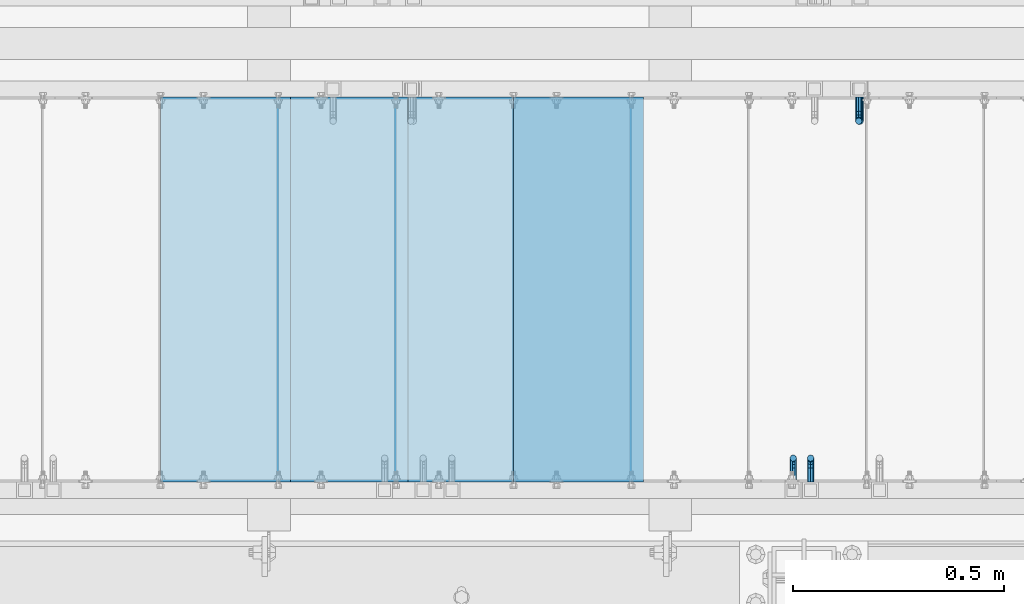
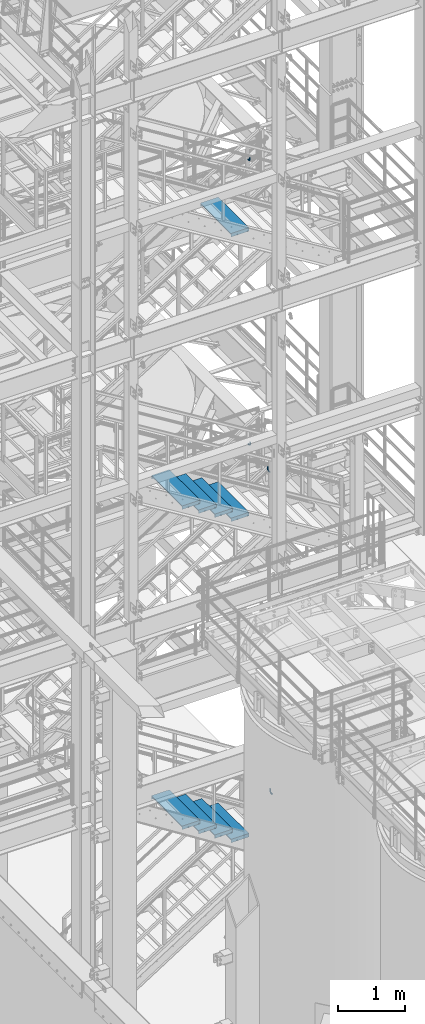
# One storey, part 1148 of 1876: 13 beams, 7 elements without a shape of their own.
"""IFC2X3 building model written with IfcOpenShell, lengths in millimetres."""

from ifc_helpers import new_model, si_unit, frame, origin_with_axes, place, context, subcontext, project, spatial, faceted_brep, material, type_object, element, aggregate, save


model = new_model("IFC2X3")

# Units and contexts
model_context = context("Model", 3, precision=1e-05, world=origin_with_axes())
body_context = subcontext(model_context, "Body", "Model", "MODEL_VIEW")
ifc_project = project(units=[si_unit("LENGTHUNIT", "METRE", prefix="MILLI"), si_unit("AREAUNIT", "SQUARE_METRE"), si_unit("VOLUMEUNIT", "CUBIC_METRE"), si_unit("MASSUNIT", "GRAM", prefix="KILO"), si_unit("TIMEUNIT", "SECOND"), si_unit("PLANEANGLEUNIT", "RADIAN"), si_unit("SOLIDANGLEUNIT", "STERADIAN"), si_unit("THERMODYNAMICTEMPERATUREUNIT", "DEGREE_CELSIUS"), si_unit("LUMINOUSINTENSITYUNIT", "LUMEN")], contexts=[model_context])

# Site, building, storey
site_placement = place(None, origin_with_axes())
site = spatial("IfcSite", under=ifc_project, at=site_placement, CompositionType="ELEMENT")
building_placement = place(site_placement, origin_with_axes())
building = spatial("IfcBuilding", under=site, at=building_placement, Name="Undefined", CompositionType="ELEMENT")
storey_placement = place(building_placement, origin_with_axes())
storey = spatial("IfcBuildingStorey", under=building, at=storey_placement, Name="Undefined", CompositionType="ELEMENT", Elevation=0.0)

# Assembly, beam
assembly_1_placement = place(storey_placement, origin_with_axes())
assembly_1 = element("IfcElementAssembly", 1, at=assembly_1_placement, inside=storey, Name="RAIL", AssemblyPlace="NOTDEFINED", PredefinedType="RIGID_FRAME")
ifc_material = material(Name="STEEL/A36")
beam_type_1 = type_object("IfcBeamType", PredefinedType="NOTDEFINED")
beam_1_placement = place(assembly_1_placement, frame((5054.60000035519, -6883.39999885446, 9800.9171377528), z_axis=(-0.851746923791363, 0.0, 0.523953411871657), x_axis=(0.0, 1.0, 0.0)))
beam_1 = element("IfcBeam", 2, at=beam_1_placement, type_object=beam_type_1, material=ifc_material, Name="BRACKET", context=body_context, shape_type="Brep", body=[
    faceted_brep([(0.0, -5.61266007566822, 5.61266007566883), (0.0, 0.0, 7.9375), (0.0, 5.61266007566822, 5.61266007566883), (0.0, 7.9375, 0.0), (0.0, 5.61266007566822, -5.61266007566883), (0.0, 0.0, -7.9375), (0.0, -5.61266007566822, -5.61266007566883), (0.0, -7.9375, 0.0), (23.8125, 7.9375, 0.0), (23.8125, 5.61266007566883, -5.61266007566792), (23.8125, 0.0, -7.9375), (23.8125, -5.61266007566883, -5.61266007566792), (23.8125, -7.9375, 0.0), (23.8125, -5.61266007566883, 5.61266007566792), (23.8125, 0.0, 7.9375), (23.8125, 5.61266007566883, 5.61266007566792), (37.2742680237907, 3.33192699189385, 7.01565649095653), (39.15743316105, 5.33771543479088, 1.59926141794483), (39.5250377726497, 2.95059483544173, -3.97508660603592), (38.1617440627024, -2.43109193407145, -6.44201010992776), (35.8661509970007, -7.65482575261558, -4.3564187624853), (33.9829858597423, -9.66061419551443, 1.05997631052549), (33.6153812481443, -7.27349359616528, 6.63432433450714), (34.9786749580899, -1.89180682665028, 9.10124783839899), (44.4449010004428, -7.27921686651098, 12.4153212945938), (48.6866038971966, -3.16305132232992, 11.0110522507902), (41.9258626896017, -12.0031473096369, 9.54377798901703), (42.605107443027, -14.5676282658369, 4.07853345752562), (46.0847428963316, -13.4704215714119, -0.778946175020906), (50.3264457930854, -9.35425602723262, -2.18321521882456), (52.8454841039247, -4.63032558410305, 0.688328086752222), (52.1662393505012, -2.0658446279067, 6.15357261824545), (56.3120829365644, -12.8834732957839, 16.9905845690854), (60.8584457511233, -13.1460552819772, 12.9695810055836), (50.7700310236578, -15.3420457780048, 17.3751827270333), (47.4787488596085, -19.0815743126295, 13.8980830945646), (48.3662248985192, -21.9114938009589, 8.59612347865811), (52.9125877130791, -22.1740757871521, 4.57511991515719), (58.4546396259857, -19.715503304933, 4.19052175720924), (61.7459217900359, -15.9759747703083, 7.66762138967886), (63.9107427334729, -26.2160548977063, 21.0096110902649), (64.8713398759373, -29.3590804831365, 15.9002591648249), (58.9897950832947, -24.3494927988595, 24.0439238549806), (52.991121319149, -24.8528009490874, 23.2257381938842), (49.4286631758196, -27.4311482600406, 19.0343361707063), (50.389260318284, -30.5741738454726, 13.9249842452672), (55.3102079684622, -32.4407359443194, 10.8906714805506), (61.3088817326088, -31.9374277940915, 11.7088571416479), (64.8713398759373, -56.6704316393188, 32.700878247072), (61.3088817326088, -56.6704314004855, 26.9234018184987), (55.3102079684622, -56.670431353863, 25.7956053568267), (50.389260318284, -56.6704315267634, 29.9781367337081), (49.4286631758196, -56.6704318179036, 37.0209257936175), (52.991121319149, -56.6704320567369, 42.7984022221907), (58.9897950832947, -56.6704321033558, 43.9261986838618), (63.9107427334739, -56.6704319304572, 39.7436673069795)], [[[0, 1, 2, 3, 4, 5, 6, 7]], [[4, 3, 8, 9]], [[5, 4, 9, 10]], [[6, 5, 10, 11]], [[7, 6, 11, 12]], [[0, 7, 12, 13]], [[1, 0, 13, 14]], [[2, 1, 14, 15]], [[3, 2, 15, 8]], [[8, 15, 16, 17]], [[9, 8, 17, 18]], [[10, 9, 18, 19]], [[11, 10, 19, 20]], [[12, 11, 20, 21]], [[13, 12, 21, 22]], [[14, 13, 22, 23]], [[15, 14, 23, 16]], [[23, 24, 25, 16]], [[22, 26, 24, 23]], [[21, 27, 26, 22]], [[20, 28, 27, 21]], [[19, 29, 28, 20]], [[18, 30, 29, 19]], [[17, 31, 30, 18]], [[16, 25, 31, 17]], [[25, 32, 33, 31]], [[24, 34, 32, 25]], [[26, 35, 34, 24]], [[27, 36, 35, 26]], [[28, 37, 36, 27]], [[29, 38, 37, 28]], [[30, 39, 38, 29]], [[31, 33, 39, 30]], [[33, 40, 41, 39]], [[32, 42, 40, 33]], [[34, 43, 42, 32]], [[35, 44, 43, 34]], [[36, 45, 44, 35]], [[37, 46, 45, 36]], [[38, 47, 46, 37]], [[39, 41, 47, 38]], [[47, 41, 48, 49]], [[46, 47, 49, 50]], [[45, 46, 50, 51]], [[44, 45, 51, 52]], [[43, 44, 52, 53]], [[42, 43, 53, 54]], [[40, 42, 54, 55]], [[41, 40, 55, 48]], [[54, 53, 52, 51, 50, 49, 48, 55]]]),
])
aggregate(assembly_1, [beam_1])

assembly_2_placement = place(storey_placement, origin_with_axes())
assembly_2 = element("IfcElementAssembly", 3, at=assembly_2_placement, inside=storey, Name="RAIL", AssemblyPlace="NOTDEFINED", PredefinedType="RIGID_FRAME")
beam_2_placement = place(assembly_2_placement, frame((5095.87500293238, -6883.39999893226, 3941.51992714005), z_axis=(-1.0, 0.0, 0.0), x_axis=(0.0, 1.0, 0.0)))
beam_2 = element("IfcBeam", 4, at=beam_2_placement, type_object=beam_type_1, material=ifc_material, Name="BRACKET", context=body_context, shape_type="Brep", body=[
    faceted_brep([(0.0, -5.61266007566822, 5.61266007566883), (0.0, 0.0, 7.9375), (0.0, 5.61266007566822, 5.61266007566883), (0.0, 7.9375, 0.0), (0.0, 5.61266007566822, -5.61266007566883), (0.0, 0.0, -7.9375), (0.0, -5.61266007566822, -5.61266007566883), (0.0, -7.9375, 0.0), (23.8125, 5.61266007566883, 5.61266007566792), (23.8125, 7.9375, 0.0), (23.8125, 5.61266007566883, -5.61266007566792), (23.8125, 0.0, -7.9375), (23.8125, -5.61266007566883, -5.61266007566792), (23.8125, -7.9375, 0.0), (23.8125, -5.61266007566883, 5.61266007566792), (23.8125, 0.0, 7.9375), (36.5702095103989, -2.53766620105534, 7.9375), (38.7180815328547, 2.64775556579752, 5.61266007566792), (39.6077592547972, 4.79562758825296, 0.0), (38.7180815328547, 2.64775556579752, -5.61266007566792), (36.5702095103989, -2.53766620105534, -7.9375), (34.4223374879439, -7.72308796790867, -5.61266007566792), (33.5326597660014, -9.87095999036364, 0.0), (34.4223374879439, -7.72308796790867, 5.61266007566792), (43.4169233967659, -13.733078129113, 5.61266007566792), (47.385673396765, -9.76432812911298, 7.9375), (41.7730133210971, -15.3769882047809, 0.0), (43.4169233967659, -13.733078129113, -5.61266007566792), (47.385673396765, -9.76432812911298, -7.9375), (51.354423396765, -5.79557812911253, -5.61266007566792), (52.9983334724338, -4.15166805344461, 0.0), (51.354423396765, -5.79557812911253, 5.61266007566792), (54.6123353248231, -20.5797920154787, 7.9375), (59.7977570916764, -18.4319199930233, 5.61266007566792), (49.4269135579698, -22.7276640379341, 5.61266007566792), (47.2790415355148, -23.6173417598766, 0.0), (49.4269135579698, -22.7276640379341, -5.61266007566792), (54.6123353248231, -20.5797920154787, -7.9375), (59.7977570916764, -18.4319199930233, -5.61266007566792), (61.9456291141314, -17.5422422710808, 0.0), (62.7626616015468, -33.3375015258789, 5.61266007566792), (65.0875015258789, -33.3375015258789, 0.0), (57.1500015258789, -33.3375015258789, 7.9375), (51.5373414502101, -33.3375015258789, 5.61266007566792), (49.2125015258789, -33.3375015258789, 0.0), (51.5373414502101, -33.3375015258789, -5.61266007566792), (57.1500015258789, -33.3375015258789, -7.9375), (62.7626616015468, -33.3375015258789, -5.61266007566792), (65.0875015258789, -66.3399314131093, 0.0), (62.7626616015468, -62.779234846751, -5.61266007566792), (57.1500015258789, -61.3043460374702, -7.9375), (51.537341450211, -62.779234846751, -5.61266007566792), (49.2125015258789, -66.3399314131093, 0.0), (51.537341450211, -69.9006279794671, 5.61266007566792), (57.1500015258789, -71.375516788748, 7.9375), (62.7626616015468, -69.9006279794671, 5.61266007566792)], [[[0, 1, 2, 3, 4, 5, 6, 7]], [[3, 2, 8, 9]], [[4, 3, 9, 10]], [[5, 4, 10, 11]], [[6, 5, 11, 12]], [[7, 6, 12, 13]], [[0, 7, 13, 14]], [[1, 0, 14, 15]], [[2, 1, 15, 8]], [[8, 15, 16, 17]], [[9, 8, 17, 18]], [[10, 9, 18, 19]], [[11, 10, 19, 20]], [[12, 11, 20, 21]], [[13, 12, 21, 22]], [[14, 13, 22, 23]], [[15, 14, 23, 16]], [[23, 24, 25, 16]], [[22, 26, 24, 23]], [[21, 27, 26, 22]], [[20, 28, 27, 21]], [[19, 29, 28, 20]], [[18, 30, 29, 19]], [[17, 31, 30, 18]], [[16, 25, 31, 17]], [[25, 32, 33, 31]], [[24, 34, 32, 25]], [[26, 35, 34, 24]], [[27, 36, 35, 26]], [[28, 37, 36, 27]], [[29, 38, 37, 28]], [[30, 39, 38, 29]], [[31, 33, 39, 30]], [[33, 40, 41, 39]], [[32, 42, 40, 33]], [[34, 43, 42, 32]], [[35, 44, 43, 34]], [[36, 45, 44, 35]], [[37, 46, 45, 36]], [[38, 47, 46, 37]], [[39, 41, 47, 38]], [[47, 41, 48, 49]], [[46, 47, 49, 50]], [[45, 46, 50, 51]], [[44, 45, 51, 52]], [[43, 44, 52, 53]], [[42, 43, 53, 54]], [[40, 42, 54, 55]], [[41, 40, 55, 48]], [[54, 53, 52, 51, 50, 49, 48, 55]]]),
])
aggregate(assembly_2, [beam_2])

assembly_3_placement = place(storey_placement, origin_with_axes())
assembly_3 = element("IfcElementAssembly", 5, at=assembly_3_placement, inside=storey, Name="RAIL", AssemblyPlace="NOTDEFINED", PredefinedType="RIGID_FRAME")
beam_3_placement = place(assembly_3_placement, frame((5213.35000046598, -5969.00000114554, 9703.26182925255), z_axis=(-1.0, 0.0, 0.0), x_axis=(0.0, -1.0, 0.0)))
beam_3 = element("IfcBeam", 6, at=beam_3_placement, type_object=beam_type_1, material=ifc_material, Name="BRACKET", context=body_context, shape_type="Brep", body=[
    faceted_brep([(0.0, -5.61266007566822, 5.61266007566883), (0.0, 0.0, 7.9375), (0.0, 5.61266007566822, 5.61266007566883), (0.0, 7.9375, 0.0), (0.0, 5.61266007566822, -5.61266007566883), (0.0, 0.0, -7.9375), (0.0, -5.61266007566822, -5.61266007566883), (0.0, -7.9375, 0.0), (23.8125, -5.61266007566883, -5.61266007566792), (23.8125, -7.9375, 0.0), (23.8125, -5.61266007566883, 5.61266007566792), (23.8125, 0.0, 7.9375), (23.8125, 5.61266007566883, 5.61266007566792), (23.8125, 7.9375, 0.0), (23.8125, 5.61266007566883, -5.61266007566792), (23.8125, 0.0, -7.9375), (36.5702095103998, 2.53766620105671, -7.9375), (38.7180815328556, -2.64775556579843, -5.61266007566792), (39.6077592547981, -4.79562758825341, 0.0), (38.7180815328556, -2.64775556579843, 5.61266007566792), (36.5702095103998, 2.53766620105671, 7.9375), (34.4223374879448, 7.72308796790821, 5.61266007566792), (33.5326597660023, 9.87095999036319, 0.0), (34.4223374879448, 7.72308796790821, -5.61266007566792), (43.4169233967659, 13.733078129113, -5.61266007566792), (47.3856733967659, 9.76432812911298, -7.9375), (41.773013321098, 15.3769882047818, 0.0), (43.4169233967659, 13.733078129113, 5.61266007566792), (47.3856733967659, 9.76432812911298, 7.9375), (51.3544233967659, 5.79557812911298, 5.61266007566792), (52.9983334724348, 4.15166805344415, 0.0), (51.3544233967659, 5.79557812911298, -5.61266007566792), (54.6123353248231, 20.5797920154801, -7.9375), (59.7977570916764, 18.4319199930251, -5.61266007566792), (49.4269135579698, 22.727664037935, -5.61266007566792), (47.2790415355148, 23.6173417598766, 0.0), (49.4269135579698, 22.727664037935, 5.61266007566792), (54.6123353248231, 20.5797920154801, 7.9375), (59.7977570916764, 18.4319199930251, 5.61266007566792), (61.9456291141314, 17.5422422710835, 0.0), (62.7626616015468, 33.3375015258789, -5.61266007566792), (65.0875015258789, 33.3375015258789, 0.0), (57.1500015258789, 33.3375015258789, -7.9375), (51.5373414502101, 33.3375015258789, -5.61266007566792), (49.2125015258789, 33.3375015258789, 0.0), (51.5373414502101, 33.3375015258789, 5.61266007566792), (57.1500015258789, 33.3375015258789, 7.9375), (62.7626616015468, 33.3375015258789, 5.61266007566792), (65.0875015258789, 66.616627667634, 0.0), (62.7626616015468, 70.0692642717895, 5.61266007566837), (57.1500015258789, 71.4993931791778, 7.9375), (51.537341450211, 70.0692642717895, 5.61266007566837), (49.2125015258789, 66.616627667634, 0.0), (51.537341450211, 63.1639910634785, -5.61266007566837), (57.1500015258789, 61.7338621560921, -7.9375), (62.7626616015468, 63.1639910634785, -5.61266007566837)], [[[0, 1, 2, 3, 4, 5, 6, 7]], [[7, 6, 8, 9]], [[0, 7, 9, 10]], [[1, 0, 10, 11]], [[2, 1, 11, 12]], [[3, 2, 12, 13]], [[4, 3, 13, 14]], [[5, 4, 14, 15]], [[6, 5, 15, 8]], [[8, 15, 16, 17]], [[9, 8, 17, 18]], [[10, 9, 18, 19]], [[11, 10, 19, 20]], [[12, 11, 20, 21]], [[13, 12, 21, 22]], [[14, 13, 22, 23]], [[15, 14, 23, 16]], [[23, 24, 25, 16]], [[22, 26, 24, 23]], [[21, 27, 26, 22]], [[20, 28, 27, 21]], [[19, 29, 28, 20]], [[18, 30, 29, 19]], [[17, 31, 30, 18]], [[16, 25, 31, 17]], [[25, 32, 33, 31]], [[24, 34, 32, 25]], [[26, 35, 34, 24]], [[27, 36, 35, 26]], [[28, 37, 36, 27]], [[29, 38, 37, 28]], [[30, 39, 38, 29]], [[31, 33, 39, 30]], [[33, 40, 41, 39]], [[32, 42, 40, 33]], [[34, 43, 42, 32]], [[35, 44, 43, 34]], [[36, 45, 44, 35]], [[37, 46, 45, 36]], [[38, 47, 46, 37]], [[39, 41, 47, 38]], [[47, 41, 48, 49]], [[46, 47, 49, 50]], [[45, 46, 50, 51]], [[44, 45, 51, 52]], [[43, 44, 52, 53]], [[42, 43, 53, 54]], [[40, 42, 54, 55]], [[41, 40, 55, 48]], [[54, 53, 52, 51, 50, 49, 48, 55]]]),
])
aggregate(assembly_3, [beam_3])

assembly_4_placement = place(storey_placement, origin_with_axes())
assembly_4 = element("IfcElementAssembly", 7, at=assembly_4_placement, inside=storey, Name="RAIL", AssemblyPlace="NOTDEFINED", PredefinedType="RIGID_FRAME")
beam_4_placement = place(assembly_4_placement, frame((5210.17500029906, -5969.00000114554, 14866.5152683235), z_axis=(-1.0, 0.0, 0.0), x_axis=(0.0, -1.0, 0.0)))
beam_4 = element("IfcBeam", 8, at=beam_4_placement, type_object=beam_type_1, material=ifc_material, Name="BRACKET", context=body_context, shape_type="Brep", body=[
    faceted_brep([(0.0, -5.61266007566822, 5.61266007566883), (0.0, 0.0, 7.9375), (0.0, 5.61266007566822, 5.61266007566883), (0.0, 7.9375, 0.0), (0.0, 5.61266007566822, -5.61266007566883), (0.0, 0.0, -7.9375), (0.0, -5.61266007566822, -5.61266007566883), (0.0, -7.9375, 0.0), (23.8125, -5.61266007566883, -5.61266007566792), (23.8125, -7.9375, 0.0), (23.8125, -5.61266007566883, 5.61266007566792), (23.8125, 0.0, 7.9375), (23.8125, 5.61266007566883, 5.61266007566792), (23.8125, 7.9375, 0.0), (23.8125, 5.61266007566883, -5.61266007566792), (23.8125, 0.0, -7.9375), (36.5702095103998, 2.53766620105671, -7.9375), (38.7180815328556, -2.64775556579843, -5.61266007566792), (39.6077592547981, -4.79562758825341, 0.0), (38.7180815328556, -2.64775556579843, 5.61266007566792), (36.5702095103998, 2.53766620105671, 7.9375), (34.4223374879448, 7.72308796790821, 5.61266007566792), (33.5326597660023, 9.87095999036319, 0.0), (34.4223374879448, 7.72308796790821, -5.61266007566792), (43.4169233967659, 13.733078129113, -5.61266007566792), (47.3856733967659, 9.76432812911298, -7.9375), (41.773013321098, 15.3769882047818, 0.0), (43.4169233967659, 13.733078129113, 5.61266007566792), (47.3856733967659, 9.76432812911298, 7.9375), (51.3544233967659, 5.79557812911298, 5.61266007566792), (52.9983334724348, 4.15166805344415, 0.0), (51.3544233967659, 5.79557812911298, -5.61266007566792), (54.6123353248231, 20.5797920154801, -7.9375), (59.7977570916764, 18.4319199930251, -5.61266007566792), (49.4269135579698, 22.727664037935, -5.61266007566792), (47.2790415355148, 23.6173417598766, 0.0), (49.4269135579698, 22.727664037935, 5.61266007566792), (54.6123353248231, 20.5797920154801, 7.9375), (59.7977570916764, 18.4319199930251, 5.61266007566792), (61.9456291141314, 17.5422422710835, 0.0), (62.7626616015468, 33.3375015258789, -5.61266007566792), (65.0875015258789, 33.3375015258789, 0.0), (57.1500015258789, 33.3375015258789, -7.9375), (51.5373414502101, 33.3375015258789, -5.61266007566792), (49.2125015258789, 33.3375015258789, 0.0), (51.5373414502101, 33.3375015258789, 5.61266007566792), (57.1500015258789, 33.3375015258789, 7.9375), (62.7626616015468, 33.3375015258789, 5.61266007566792), (65.0875015258789, 66.5774551740215, 0.0), (62.7626616015468, 70.0546586046949, 5.61266007566792), (57.1500015258789, 71.4949634248096, 7.9375), (51.537341450211, 70.0546586046949, 5.61266007566792), (49.2125015258789, 66.5774551740215, 0.0), (51.537341450211, 63.1002517433481, -5.61266007566792), (57.1500015258789, 61.6599469232333, -7.9375), (62.7626616015468, 63.1002517433481, -5.61266007566792)], [[[0, 1, 2, 3, 4, 5, 6, 7]], [[7, 6, 8, 9]], [[0, 7, 9, 10]], [[1, 0, 10, 11]], [[2, 1, 11, 12]], [[3, 2, 12, 13]], [[4, 3, 13, 14]], [[5, 4, 14, 15]], [[6, 5, 15, 8]], [[8, 15, 16, 17]], [[9, 8, 17, 18]], [[10, 9, 18, 19]], [[11, 10, 19, 20]], [[12, 11, 20, 21]], [[13, 12, 21, 22]], [[14, 13, 22, 23]], [[15, 14, 23, 16]], [[23, 24, 25, 16]], [[22, 26, 24, 23]], [[21, 27, 26, 22]], [[20, 28, 27, 21]], [[19, 29, 28, 20]], [[18, 30, 29, 19]], [[17, 31, 30, 18]], [[16, 25, 31, 17]], [[25, 32, 33, 31]], [[24, 34, 32, 25]], [[26, 35, 34, 24]], [[27, 36, 35, 26]], [[28, 37, 36, 27]], [[29, 38, 37, 28]], [[30, 39, 38, 29]], [[31, 33, 39, 30]], [[33, 40, 41, 39]], [[32, 42, 40, 33]], [[34, 43, 42, 32]], [[35, 44, 43, 34]], [[36, 45, 44, 35]], [[37, 46, 45, 36]], [[38, 47, 46, 37]], [[39, 41, 47, 38]], [[47, 41, 48, 49]], [[46, 47, 49, 50]], [[45, 46, 50, 51]], [[44, 45, 51, 52]], [[43, 44, 52, 53]], [[42, 43, 53, 54]], [[40, 42, 54, 55]], [[41, 40, 55, 48]], [[54, 53, 52, 51, 50, 49, 48, 55]]]),
])
aggregate(assembly_4, [beam_4])

assembly_5_placement = place(storey_placement, origin_with_axes())
assembly_5 = element("IfcElementAssembly", 9, at=assembly_5_placement, inside=storey, Name="STRINGER", AssemblyPlace="NOTDEFINED", PredefinedType="RIGID_FRAME")
beam_type_2 = type_object("IfcBeamType", PredefinedType="NOTDEFINED")
beam_5_placement = place(assembly_5_placement, frame((4545.01250085489, -5973.76300114663, 14348.1777777782), z_axis=(1.0, 0.0, 0.0), x_axis=(0.0, -1.0, 0.0)))
beam_5 = element("IfcBeam", 10, at=beam_5_placement, type_object=beam_type_2, material=ifc_material, Name="TREAD", context=body_context, shape_type="Brep", body=[
    faceted_brep([(-7.45785655453801e-11, 53.9750000000167, -153.9875), (-7.45785655453801e-11, 53.9750000000167, 153.987506103515), (0.0, 9.52499999999964, 153.9875), (-7.45785655453801e-11, 9.52499999999964, -153.9875), (-4.76300000007541, 53.9750000000167, -153.9875), (-4.76300000007541, 53.9750000000167, 153.987506103515), (-4.76300000007541, -9.52499999998327, -153.9875), (-4.76300000007541, -9.52500000019427, 153.987536621094), (909.637000008669, 53.9749999975102, 153.987506103515), (904.87400000867, 53.9749999975102, 153.987506103515), (904.87400000867, 9.52499999999964, 153.987506103515), (909.637000008669, -9.52500000248983, 153.987506103515), (904.87400000867, 9.52499999999964, -153.9875), (909.637000008669, -9.52500000248983, -153.9875), (909.637000008669, 53.9749999975102, -153.9875), (904.87400000867, 53.9749999975102, -153.9875)], [[[0, 1, 2, 3]], [[1, 0, 4, 5]], [[5, 4, 6, 7]], [[8, 9, 10, 2, 1, 5, 7, 11]], [[12, 3, 2, 10]], [[13, 11, 7, 6]], [[8, 14, 15, 9]], [[14, 8, 11, 13]], [[14, 13, 6, 4, 0, 3, 12, 15]], [[9, 15, 12, 10]]]),
])
aggregate(assembly_5, [beam_5])

# Assembly, beams
assembly_6_placement = place(storey_placement, origin_with_axes())
assembly_6 = element("IfcElementAssembly", 11, at=assembly_6_placement, inside=storey, Name="STRINGER", AssemblyPlace="NOTDEFINED", PredefinedType="RIGID_FRAME")
beam_6_placement = place(assembly_6_placement, frame((3706.81250087221, -5973.76300114521, 9700.26000057626), z_axis=(1.0, 0.0, 0.0), x_axis=(0.0, -1.0, 0.0)))
beam_6 = element("IfcBeam", 12, at=beam_6_placement, type_object=beam_type_2, material=ifc_material, Name="TREAD", context=body_context, shape_type="Brep", body=[
    faceted_brep([(-7.45785655453801e-11, 53.9750000000167, -153.9875), (-7.45785655453801e-11, 53.9750000000167, 153.987506103515), (0.0, 9.52499999999964, 153.9875), (-7.45785655453801e-11, 9.52499999999964, -153.9875), (-4.76300000007541, 53.9750000000167, -153.9875), (-4.76300000007541, 53.9750000000167, 153.987506103515), (-4.76300000007541, -9.52499999998327, -153.9875), (-4.76300000007541, -9.52500000019427, 153.987536621094), (909.637000008669, -9.52500000248983, 153.987506103515), (909.637000008669, 53.9749999975102, 153.987506103515), (904.87400000867, 53.9749999975102, 153.987506103515), (904.87400000867, 9.52499999999964, 153.987506103515), (-7.45785655453801e-11, -9.52500000019427, 153.987536621094), (904.87400000867, -9.52500000248983, 153.987506103515), (904.87400000867, 9.52499999999964, -153.9875), (909.637000008669, -9.52500000248983, -153.9875), (909.637000008669, 53.9749999975102, -153.9875), (904.87400000867, 53.9749999975102, -153.9875)], [[[0, 1, 2, 3]], [[1, 0, 4, 5]], [[5, 4, 6, 7]], [[8, 9, 10, 11, 2, 1, 5, 7, 12, 13]], [[14, 3, 2, 11]], [[15, 8, 13, 12, 7, 6]], [[9, 16, 17, 10]], [[16, 9, 8, 15]], [[16, 15, 6, 4, 0, 3, 14, 17]], [[10, 17, 14, 11]]]),
])
beam_7_placement = place(assembly_6_placement, frame((3986.21250080267, -5973.76300114546, 9528.38666717907), z_axis=(1.0, 0.0, 0.0), x_axis=(0.0, -1.0, 0.0)))
beam_7 = element("IfcBeam", 13, at=beam_7_placement, type_object=beam_type_2, material=ifc_material, Name="TREAD", context=body_context, shape_type="Brep", body=[
    faceted_brep([(-7.45785655453801e-11, 53.9750000000167, -153.9875), (-7.45785655453801e-11, 53.9750000000167, 153.987506103515), (0.0, 9.52499999999964, 153.9875), (-7.45785655453801e-11, 9.52499999999964, -153.9875), (-4.76300000007541, 53.9750000000167, -153.9875), (-4.76300000007541, 53.9750000000167, 153.987506103515), (-4.76300000007541, -9.52499999998327, -153.9875), (-4.76300000007541, -9.52500000019427, 153.987536621094), (909.637000008669, -9.52500000248983, 153.987506103515), (909.637000008669, 53.9749999975102, 153.987506103515), (904.87400000867, 53.9749999975102, 153.987506103515), (904.87400000867, 9.52499999999964, 153.987506103515), (-7.45785655453801e-11, -9.52500000019427, 153.987536621094), (904.87400000867, -9.52500000248983, 153.987506103515), (904.87400000867, 9.52499999999964, -153.9875), (909.637000008669, -9.52500000248983, -153.9875), (909.637000008669, 53.9749999975102, -153.9875), (904.87400000867, 53.9749999975102, -153.9875)], [[[0, 1, 2, 3]], [[1, 0, 4, 5]], [[5, 4, 6, 7]], [[8, 9, 10, 11, 2, 1, 5, 7, 12, 13]], [[14, 3, 2, 11]], [[15, 8, 13, 12, 7, 6]], [[9, 16, 17, 10]], [[16, 9, 8, 15]], [[16, 15, 6, 4, 0, 3, 14, 17]], [[10, 17, 14, 11]]]),
])
beam_8_placement = place(assembly_6_placement, frame((4265.61250073313, -5973.76300114571, 9356.51333378189), z_axis=(1.0, 0.0, 0.0), x_axis=(0.0, -1.0, 0.0)))
beam_8 = element("IfcBeam", 14, at=beam_8_placement, type_object=beam_type_2, material=ifc_material, Name="TREAD", context=body_context, shape_type="Brep", body=[
    faceted_brep([(-7.45785655453801e-11, 53.9750000000167, -153.9875), (-7.45785655453801e-11, 53.9750000000167, 153.987506103515), (0.0, 9.52499999999964, 153.9875), (-7.45785655453801e-11, 9.52499999999964, -153.9875), (-4.76300000007541, 53.9750000000167, -153.9875), (-4.76300000007541, 53.9750000000167, 153.987506103515), (-4.76300000007541, -9.52499999998327, -153.9875), (-4.76300000007541, -9.52500000019427, 153.987536621094), (909.637000008669, -9.52500000248983, 153.987506103515), (909.637000008669, 53.9749999975102, 153.987506103515), (904.87400000867, 53.9749999975102, 153.987506103515), (904.87400000867, 9.52499999999964, 153.987506103515), (-7.45785655453801e-11, -9.52500000019427, 153.987536621094), (904.87400000867, -9.52500000248983, 153.987506103515), (904.87400000867, 9.52499999999964, -153.9875), (909.637000008669, -9.52500000248983, -153.9875), (909.637000008669, 53.9749999975102, -153.9875), (904.87400000867, 53.9749999975102, -153.9875)], [[[0, 1, 2, 3]], [[1, 0, 4, 5]], [[5, 4, 6, 7]], [[8, 9, 10, 11, 2, 1, 5, 7, 12, 13]], [[14, 3, 2, 11]], [[15, 8, 13, 12, 7, 6]], [[9, 16, 17, 10]], [[16, 9, 8, 15]], [[16, 15, 6, 4, 0, 3, 14, 17]], [[10, 17, 14, 11]]]),
])
beam_9_placement = place(assembly_6_placement, frame((4545.01250066359, -5973.76300114597, 9184.64000038471), z_axis=(1.0, 0.0, 0.0), x_axis=(0.0, -1.0, 0.0)))
beam_9 = element("IfcBeam", 15, at=beam_9_placement, type_object=beam_type_2, material=ifc_material, Name="TREAD", context=body_context, shape_type="Brep", body=[
    faceted_brep([(-7.45785655453801e-11, 53.9750000000167, -153.9875), (-7.45785655453801e-11, 53.9750000000167, 153.987506103515), (0.0, 9.52499999999964, 153.9875), (-7.45785655453801e-11, 9.52499999999964, -153.9875), (-4.76300000007541, 53.9750000000167, -153.9875), (-4.76300000007541, 53.9750000000167, 153.987506103515), (-4.76300000007541, -9.52499999998327, -153.9875), (-4.76300000007541, -9.52500000019427, 153.987536621094), (909.637000008669, -9.52500000248983, 153.987506103515), (909.637000008669, 53.9749999975102, 153.987506103515), (904.87400000867, 53.9749999975102, 153.987506103515), (904.87400000867, 9.52499999999964, 153.987506103515), (-7.45785655453801e-11, -9.52500000019427, 153.987536621094), (904.87400000867, -9.52500000248983, 153.987506103515), (904.87400000867, 9.52499999999964, -153.9875), (909.637000008669, -9.52500000248983, -153.9875), (909.637000008669, 53.9749999975102, -153.9875), (904.87400000867, 53.9749999975102, -153.9875)], [[[0, 1, 2, 3]], [[1, 0, 4, 5]], [[5, 4, 6, 7]], [[8, 9, 10, 11, 2, 1, 5, 7, 12, 13]], [[14, 3, 2, 11]], [[15, 8, 13, 12, 7, 6]], [[9, 16, 17, 10]], [[16, 9, 8, 15]], [[16, 15, 6, 4, 0, 3, 14, 17]], [[10, 17, 14, 11]]]),
])
aggregate(assembly_6, [beam_6, beam_7, beam_8, beam_9])

assembly_7_placement = place(storey_placement, origin_with_axes())
assembly_7 = element("IfcElementAssembly", 16, at=assembly_7_placement, inside=storey, Name="STRINGER", AssemblyPlace="NOTDEFINED", PredefinedType="RIGID_FRAME")
beam_10_placement = place(assembly_7_placement, frame((3706.81250388274, -5973.76300113325, 3890.03189655521), z_axis=(1.0, 0.0, 0.0), x_axis=(0.0, -1.0, 0.0)))
beam_10 = element("IfcBeam", 17, at=beam_10_placement, type_object=beam_type_2, material=ifc_material, Name="TREAD", context=body_context, shape_type="Brep", body=[
    faceted_brep([(-7.45785655453801e-11, 53.9750000000167, -153.9875), (-7.45785655453801e-11, 53.9750000000167, 153.987506103515), (0.0, 9.52499999999964, 153.9875), (-7.45785655453801e-11, 9.52499999999964, -153.9875), (-4.76300000007541, 53.9750000000167, -153.9875), (-4.76300000007541, 53.9750000000167, 153.987506103515), (-4.76300000007541, -9.52499999998327, -153.9875), (-4.76300000007541, -9.52500000019427, 153.987536621094), (909.637000008669, -9.52500000248983, 153.987506103515), (909.637000008669, 53.9749999975102, 153.987506103515), (904.87400000867, 53.9749999975102, 153.987506103515), (904.87400000867, 9.52499999999964, 153.987506103515), (-7.45785655453801e-11, -9.52500000019427, 153.987536621094), (904.87400000867, -9.52500000248983, 153.987506103515), (904.87400000867, 9.52499999999964, -153.9875), (909.637000008669, -9.52500000248983, -153.9875), (909.637000008669, 53.9749999975102, -153.9875), (904.87400000867, 53.9749999975102, -153.9875)], [[[0, 1, 2, 3]], [[1, 0, 4, 5]], [[5, 4, 6, 7]], [[8, 9, 10, 11, 2, 1, 5, 7, 12, 13]], [[14, 3, 2, 11]], [[15, 8, 13, 12, 7, 6]], [[9, 16, 17, 10]], [[16, 9, 8, 15]], [[16, 15, 6, 4, 0, 3, 14, 17]], [[10, 17, 14, 11]]]),
])
beam_11_placement = place(assembly_7_placement, frame((3986.21250356494, -5973.76300113309, 3712.77931034857), z_axis=(1.0, 0.0, 0.0), x_axis=(0.0, -1.0, 0.0)))
beam_11 = element("IfcBeam", 18, at=beam_11_placement, type_object=beam_type_2, material=ifc_material, Name="TREAD", context=body_context, shape_type="Brep", body=[
    faceted_brep([(-7.45785655453801e-11, 53.9750000000167, -153.9875), (-7.45785655453801e-11, 53.9750000000167, 153.987506103515), (0.0, 9.52499999999964, 153.9875), (-7.45785655453801e-11, 9.52499999999964, -153.9875), (-4.76300000007541, 53.9750000000167, -153.9875), (-4.76300000007541, 53.9750000000167, 153.987506103515), (-4.76300000007541, -9.52499999998327, -153.9875), (-4.76300000007541, -9.52500000019427, 153.987536621094), (909.637000008669, -9.52500000248983, 153.987506103515), (909.637000008669, 53.9749999975102, 153.987506103515), (904.87400000867, 53.9749999975102, 153.987506103515), (904.87400000867, 9.52499999999964, 153.987506103515), (-7.45785655453801e-11, -9.52500000019427, 153.987536621094), (904.87400000867, -9.52500000248983, 153.987506103515), (904.87400000867, 9.52499999999964, -153.9875), (909.637000008669, -9.52500000248983, -153.9875), (909.637000008669, 53.9749999975102, -153.9875), (904.87400000867, 53.9749999975102, -153.9875)], [[[0, 1, 2, 3]], [[1, 0, 4, 5]], [[5, 4, 6, 7]], [[8, 9, 10, 11, 2, 1, 5, 7, 12, 13]], [[14, 3, 2, 11]], [[15, 8, 13, 12, 7, 6]], [[9, 16, 17, 10]], [[16, 9, 8, 15]], [[16, 15, 6, 4, 0, 3, 14, 17]], [[10, 17, 14, 11]]]),
])
beam_12_placement = place(assembly_7_placement, frame((4265.61250324713, -5973.76300113293, 3535.52672414193), z_axis=(1.0, 0.0, 0.0), x_axis=(0.0, -1.0, 0.0)))
beam_12 = element("IfcBeam", 19, at=beam_12_placement, type_object=beam_type_2, material=ifc_material, Name="TREAD", context=body_context, shape_type="Brep", body=[
    faceted_brep([(-7.45785655453801e-11, 53.9750000000167, -153.9875), (-7.45785655453801e-11, 53.9750000000167, 153.987506103515), (0.0, 9.52499999999964, 153.9875), (-7.45785655453801e-11, 9.52499999999964, -153.9875), (-4.76300000007541, 53.9750000000167, -153.9875), (-4.76300000007541, 53.9750000000167, 153.987506103515), (-4.76300000007541, -9.52499999998327, -153.9875), (-4.76300000007541, -9.52500000019427, 153.987536621094), (909.637000008669, -9.52500000248983, 153.987506103515), (909.637000008669, 53.9749999975102, 153.987506103515), (904.87400000867, 53.9749999975102, 153.987506103515), (904.87400000867, 9.52499999999964, 153.987506103515), (-7.45785655453801e-11, -9.52500000019427, 153.987536621094), (904.87400000867, -9.52500000248983, 153.987506103515), (904.87400000867, 9.52499999999964, -153.9875), (909.637000008669, -9.52500000248983, -153.9875), (909.637000008669, 53.9749999975102, -153.9875), (904.87400000867, 53.9749999975102, -153.9875)], [[[0, 1, 2, 3]], [[1, 0, 4, 5]], [[5, 4, 6, 7]], [[8, 9, 10, 11, 2, 1, 5, 7, 12, 13]], [[14, 3, 2, 11]], [[15, 8, 13, 12, 7, 6]], [[9, 16, 17, 10]], [[16, 9, 8, 15]], [[16, 15, 6, 4, 0, 3, 14, 17]], [[10, 17, 14, 11]]]),
])
beam_13_placement = place(assembly_7_placement, frame((4545.01250292933, -5973.76300113277, 3358.27413793528), z_axis=(1.0, 0.0, 0.0), x_axis=(0.0, -1.0, 0.0)))
beam_13 = element("IfcBeam", 20, at=beam_13_placement, type_object=beam_type_2, material=ifc_material, Name="TREAD", context=body_context, shape_type="Brep", body=[
    faceted_brep([(-7.45785655453801e-11, 53.9750000000167, -153.9875), (-7.45785655453801e-11, 53.9750000000167, 153.987506103515), (0.0, 9.52499999999964, 153.9875), (-7.45785655453801e-11, 9.52499999999964, -153.9875), (-4.76300000007541, 53.9750000000167, -153.9875), (-4.76300000007541, 53.9750000000167, 153.987506103515), (-4.76300000007541, -9.52499999998327, -153.9875), (-4.76300000007541, -9.52500000019427, 153.987536621094), (909.637000008669, -9.52500000248983, 153.987506103515), (909.637000008669, 53.9749999975102, 153.987506103515), (904.87400000867, 53.9749999975102, 153.987506103515), (904.87400000867, 9.52499999999964, 153.987506103515), (-7.45785655453801e-11, -9.52500000019427, 153.987536621094), (904.87400000867, -9.52500000248983, 153.987506103515), (904.87400000867, 9.52499999999964, -153.9875), (909.637000008669, -9.52500000248983, -153.9875), (909.637000008669, 53.9749999975102, -153.9875), (904.87400000867, 53.9749999975102, -153.9875)], [[[0, 1, 2, 3]], [[1, 0, 4, 5]], [[5, 4, 6, 7]], [[8, 9, 10, 11, 2, 1, 5, 7, 12, 13]], [[14, 3, 2, 11]], [[15, 8, 13, 12, 7, 6]], [[9, 16, 17, 10]], [[16, 9, 8, 15]], [[16, 15, 6, 4, 0, 3, 14, 17]], [[10, 17, 14, 11]]]),
])
aggregate(assembly_7, [beam_10, beam_11, beam_12, beam_13])

save(model, "model.ifc")
